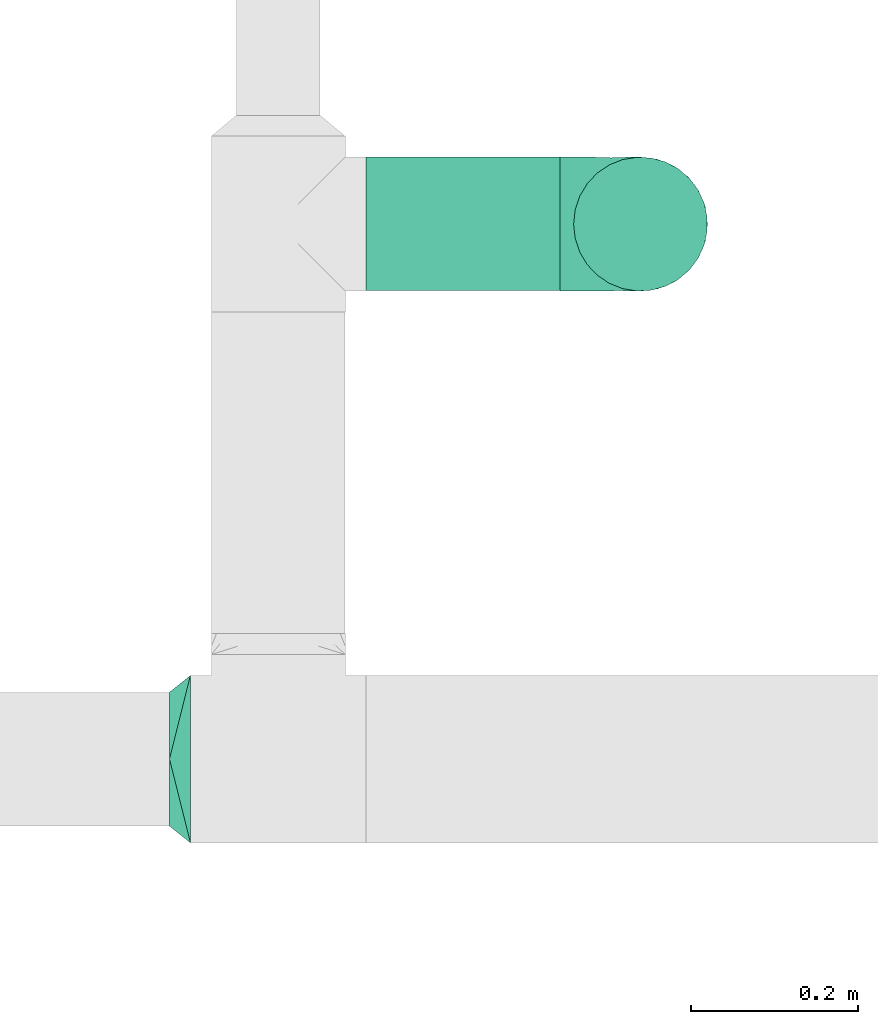
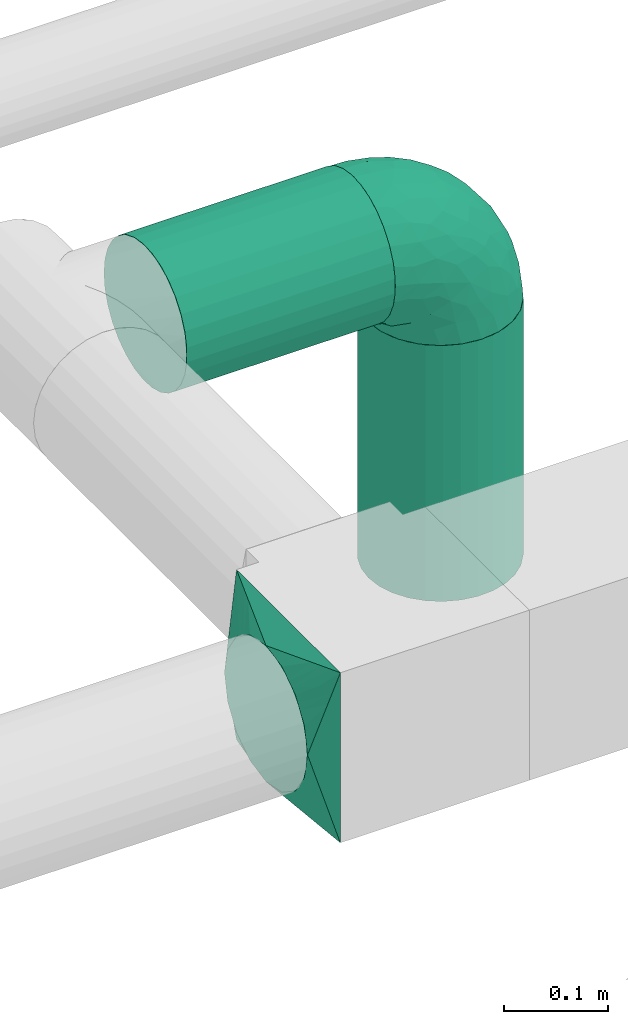
# One storey, part 8 of 12: 2 flow fittings, 2 flow segments.
"""IFC2X3 building model written with IfcOpenShell, lengths in millimetres."""

import ifcopenshell
import ifcopenshell.guid

model = None  # the IFC model being written
_history = None  # IfcOwnerHistory: only IFC2X3 demands one
_inside = {}  # id of a spatial element -> (the spatial element, [elements in it])
_under = {}  # id of a project, library or spatial element -> (it, [spatial elements below it])
_declared = {}  # id of a project -> (the project, [libraries it declares])
_typed = {}  # id of a type object -> (the type object, [elements of that type])
_made_of = {}  # id of a material, layer set ... -> (it, [elements and type objects made of it])


def new_model(schema):
    """Start an empty IFC model of exactly this schema.

    Asked for "IFC4X3", IfcOpenShell would pick the latest addendum, in which some entities
    have other attributes; the version numbers below select the first issue.
    IFC2X3 requires an IfcOwnerHistory on every rooted entity: one is made here for all.
    """
    global model, _history
    if schema == "IFC4X3":
        model = ifcopenshell.file(schema_version=(4, 3, 0, 0))
    else:
        model = ifcopenshell.file(schema=schema)
    _inside.clear()
    _under.clear()
    _declared.clear()
    _typed.clear()
    _made_of.clear()
    _history = None
    if model.schema == "IFC2X3":
        org = make("IfcOrganization", Name="unknown")
        user = make(
            "IfcPersonAndOrganization",
            ThePerson=make("IfcPerson", FamilyName="unknown"),
            TheOrganization=org,
        )
        app = make(
            "IfcApplication",
            ApplicationDeveloper=org,
            Version="unknown",
            ApplicationFullName="unknown",
            ApplicationIdentifier="unknown",
        )
        _history = make(
            "IfcOwnerHistory",
            OwningUser=user,
            OwningApplication=app,
            ChangeAction="ADDED",
            CreationDate=0,
        )
    return model


def make(cls, **values):
    """One entity of the class cls with the attributes given. An attribute that is None is left unset."""
    return model.create_entity(
        cls, **{name: value for name, value in values.items() if value is not None}
    )


def entity(cls, *values):
    """Any entity or typed value of the class cls, its attributes in the order of the schema. None: left unset."""
    e = model.create_entity(cls)
    for i, value in enumerate(values):
        if value is not None:
            e[i] = value
    return e


def rooted(cls, **values):
    """An entity with a GlobalId (a new one), such as an element, a storey or a relation."""
    return make(cls, GlobalId=ifcopenshell.guid.new(), OwnerHistory=_history, **values)


def si_unit(unit_type, name, prefix=None):
    """IfcSIUnit, for example si_unit("LENGTHUNIT", "METRE", prefix="MILLI")."""
    return make("IfcSIUnit", UnitType=unit_type, Prefix=prefix, Name=name)


def converted_unit(unit_type, name, factor, base, dimensions=None, offset=None):
    """IfcConversionBasedUnit, such as the inch: factor (a typed value) times the base unit."""
    return make(
        "IfcConversionBasedUnit"
        if offset is None
        else "IfcConversionBasedUnitWithOffset",
        ConversionOffset=offset,
        Dimensions=None
        if dimensions is None
        else entity("IfcDimensionalExponents", *dimensions),
        UnitType=unit_type,
        Name=name,
        ConversionFactor=make(
            "IfcMeasureWithUnit", ValueComponent=factor, UnitComponent=base
        ),
    )


def derived_unit(unit_type, elements):
    """IfcDerivedUnit: a product of units, each with its exponent."""
    return make(
        "IfcDerivedUnit",
        Elements=[
            make("IfcDerivedUnitElement", Unit=unit, Exponent=power)
            for unit, power in elements
        ],
        UnitType=unit_type,
    )


def assignment(units):
    """IfcUnitAssignment: the units of a project."""
    return None if units is None else make("IfcUnitAssignment", Units=units)


def point(xyz):
    """IfcCartesianPoint."""
    return None if xyz is None else make("IfcCartesianPoint", Coordinates=xyz)


def direction(xyz):
    """IfcDirection."""
    return None if xyz is None else make("IfcDirection", DirectionRatios=xyz)


def frame(location, z_axis=None, x_axis=None):
    """IfcAxis2Placement3D, a coordinate frame: its origin and axes. An axis left out is left unset."""
    return make(
        "IfcAxis2Placement3D",
        Location=point(location),
        Axis=direction(z_axis),
        RefDirection=direction(x_axis),
    )


def frame_2d(location, x_axis=None):
    """IfcAxis2Placement2D, a coordinate frame in the plane: its origin and x axis."""
    return make(
        "IfcAxis2Placement2D", Location=point(location), RefDirection=direction(x_axis)
    )


def origin():
    """The frame at (0, 0, 0) with its axes left unset."""
    return frame((0.0, 0.0, 0.0))


def origin_2d_with_axis():
    """The frame at (0, 0) in the plane with the x axis (1, 0) written out."""
    return frame_2d((0.0, 0.0), x_axis=(1.0, 0.0))


def place(relative_to, where):
    """IfcLocalPlacement: puts the frame where relative to a parent placement (None: the world)."""
    return make(
        "IfcLocalPlacement", PlacementRelTo=relative_to, RelativePlacement=where
    )


def context(
    kind, dimensions, precision=None, world=None, true_north=None, identifier=None
):
    """IfcGeometricRepresentationContext, for example the 3D "Model" context."""
    return make(
        "IfcGeometricRepresentationContext",
        ContextIdentifier=identifier,
        ContextType=kind,
        CoordinateSpaceDimension=dimensions,
        Precision=precision,
        WorldCoordinateSystem=world,
        TrueNorth=true_north,
    )


def subcontext(parent, identifier, kind, view, scale=None):
    """IfcGeometricRepresentationSubContext, for example "Body" below "Model"."""
    return make(
        "IfcGeometricRepresentationSubContext",
        ContextIdentifier=identifier,
        ContextType=kind,
        ParentContext=parent,
        TargetScale=scale,
        TargetView=view,
    )


def project(units=None, contexts=None):
    """IfcProject with its units and contexts."""
    return rooted(
        "IfcProject",
        Name="project",
        RepresentationContexts=contexts,
        UnitsInContext=assignment(units),
    )


def spatial(cls, under=None, at=None, **own):
    """A site, building, storey or space (cls), placed at a placement, below another one or the project."""
    s = rooted(cls, ObjectPlacement=at, **own)
    if under is not None:
        _under.setdefault(under.id(), (under, []))[1].append(s)
    return s


def profile(cls, at=None, kind="AREA", **sizes):
    """A parametric profile (cls). Its sizes go by their IFC names, for example OverallWidth=200.0."""
    return make(cls, ProfileType=kind, Position=at, **sizes)


def circle(**sizes):
    """IfcCircleProfileDef."""
    return profile("IfcCircleProfileDef", **sizes)


def extrude(swept, where, along, depth):
    """IfcExtrudedAreaSolid: the profile swept, set in the frame where, extruded along a direction by depth."""
    return make(
        "IfcExtrudedAreaSolid",
        SweptArea=swept,
        Position=where,
        ExtrudedDirection=direction(along),
        Depth=depth,
    )


def faces_of(points, faces, orient=None, outer=None):
    """IfcFace entities. A face is a list of loops; a loop is a list of indices into points, from 0.

    orient and outer hold one flag for each loop. By default every Orientation is true, the
    first loop of a face is its IfcFaceOuterBound and the others are IfcFaceBound.
    """
    made = []
    for i, loops in enumerate(faces):
        bounds = []
        for j, loop in enumerate(loops):
            is_outer = j == 0 if outer is None else outer[i][j]
            bounds.append(
                make(
                    "IfcFaceOuterBound" if is_outer else "IfcFaceBound",
                    Bound=make("IfcPolyLoop", Polygon=[points[k] for k in loop]),
                    Orientation=True if orient is None else orient[i][j],
                )
            )
        made.append(make("IfcFace", Bounds=bounds))
    return made


def faceted_brep(points, faces, orient=None, outer=None, voids=None):
    """IfcFacetedBrep: a solid bounded by flat faces; with voids (closed shells), ...WithVoids."""
    shared = [point(p) for p in points]
    hull = make("IfcClosedShell", CfsFaces=faces_of(shared, faces, orient, outer))
    if voids is None:
        return make("IfcFacetedBrep", Outer=hull)
    return make(
        "IfcFacetedBrepWithVoids",
        Outer=hull,
        Voids=[
            make(cls, CfsFaces=faces_of(shared, fs, o, b)) for cls, fs, o, b in voids
        ],
    )


def shape(context_of_items, identifier, shape_type, items):
    """IfcShapeRepresentation: the items that make up one representation, for example the "Body"."""
    return make(
        "IfcShapeRepresentation",
        ContextOfItems=context_of_items,
        RepresentationIdentifier=identifier,
        RepresentationType=shape_type,
        Items=items,
    )


def source(mapping_origin, context_of_items, identifier, shape_type, items):
    """IfcRepresentationMap: a shape defined once, which mapped items show again and again."""
    return make(
        "IfcRepresentationMap",
        MappingOrigin=mapping_origin,
        MappedRepresentation=shape(context_of_items, identifier, shape_type, items),
    )


def transform(
    local_origin,
    x_axis=None,
    y_axis=None,
    z_axis=None,
    scale=None,
    scale2=None,
    scale3=None,
    uniform=True,
):
    """IfcCartesianTransformationOperator3D, or its non-uniform kind. x_axis, y_axis, z_axis: its Axis1, 2, 3."""
    if uniform:
        return make(
            "IfcCartesianTransformationOperator3D",
            Axis1=direction(x_axis),
            Axis2=direction(y_axis),
            LocalOrigin=point(local_origin),
            Scale=scale,
            Axis3=direction(z_axis),
        )
    return make(
        "IfcCartesianTransformationOperator3DnonUniform",
        Axis1=direction(x_axis),
        Axis2=direction(y_axis),
        LocalOrigin=point(local_origin),
        Scale=scale,
        Axis3=direction(z_axis),
        Scale2=scale2,
        Scale3=scale3,
    )


def mapped(mapping_source, mapping_target):
    """IfcMappedItem: shows the shape of a source again, moved by a transform."""
    return make(
        "IfcMappedItem", MappingSource=mapping_source, MappingTarget=mapping_target
    )


def material(Name=None, Category=None):
    """IfcMaterial."""
    return make("IfcMaterial", Name=Name, Category=Category)


def made_of(thing, what):
    """Note that an element or type object is made of a material, layer set ...; save() writes the relation."""
    if what is not None:
        _made_of.setdefault(what.id(), (what, []))[1].append(thing)
    return thing


def type_object(cls, material=None, **own):
    """A type object (cls), such as IfcWallType, which elements share."""
    return made_of(rooted(cls, **own), material)


def type_shapes(of_type, sources):
    """Give a type object the sources (RepresentationMaps) that its elements show as mapped items."""
    of_type.RepresentationMaps = sources


def element(
    cls,
    number,
    at=None,
    inside=None,
    cuts=None,
    type_object=None,
    material=None,
    context=None,
    identifier="Body",
    shape_type=None,
    held_by="IfcProductDefinitionShape",
    body=None,
    shapes=None,
    **own,
):
    """One element of the class cls, such as IfcWall. Its Tag is "e" and its number.

    at: its placement. inside: the storey or other place that contains it. cuts: it is an
    opening in that element (IfcRelVoidsElement). A single representation is given by context,
    identifier, shape_type and body (its items); several are given by shapes. held_by: the class
    of the entity that holds the representations. save() writes the other relations.
    """
    e = rooted(cls, Tag="e%d" % number, ObjectPlacement=at, **own)
    if body is not None:
        shapes = [shape(context, identifier, shape_type, body)]
    if shapes is not None:
        e.Representation = make(held_by, Representations=shapes)
    if inside is not None:
        _inside.setdefault(inside.id(), (inside, []))[1].append(e)
    if cuts is not None:
        rooted(
            "IfcRelVoidsElement", RelatingBuildingElement=cuts, RelatedOpeningElement=e
        )
    if type_object is not None:
        _typed.setdefault(type_object.id(), (type_object, []))[1].append(e)
    return made_of(e, material)


def aggregate(whole, parts):
    """IfcRelAggregates: a whole, such as a stair, and the parts it consists of."""
    return rooted("IfcRelAggregates", RelatingObject=whole, RelatedObjects=parts)


def save(model, path):
    """Write the relations noted so far, then the file.

    IfcRelAggregates (storeys below a building ...), IfcRelContainedInSpatialStructure (elements
    in a storey), IfcRelDefinesByType, IfcRelAssociatesMaterial and IfcRelDeclares: one each for
    every whole, place, type object, material and project.
    """
    for whole, parts in _under.values():
        aggregate(whole, parts)
    for where, things in _inside.values():
        rooted(
            "IfcRelContainedInSpatialStructure",
            RelatedElements=things,
            RelatingStructure=where,
        )
    for kind, things in _typed.values():
        rooted("IfcRelDefinesByType", RelatedObjects=things, RelatingType=kind)
    for what, things in _made_of.values():
        rooted("IfcRelAssociatesMaterial", RelatedObjects=things, RelatingMaterial=what)
    for by, libraries in _declared.values():
        rooted("IfcRelDeclares", RelatingContext=by, RelatedDefinitions=libraries)
    model.write(path)


model = new_model("IFC2X3")

# Units and contexts
model_context = context("Model", 3, precision=0.01, world=origin(), true_north=direction((6.12303176911189e-17, 1.0)))
body_context = subcontext(model_context, "Body", "Model", "MODEL_VIEW")
ifc_project = project(units=[si_unit("LENGTHUNIT", "METRE", prefix="MILLI"), si_unit("AREAUNIT", "SQUARE_METRE"), si_unit("VOLUMEUNIT", "CUBIC_METRE"), converted_unit("PLANEANGLEUNIT", "DEGREE", entity("IfcRatioMeasure", 0.0174532925199433), si_unit("PLANEANGLEUNIT", "RADIAN"), dimensions=[0, 0, 0, 0, 0, 0, 0]), si_unit("MASSUNIT", "GRAM", prefix="KILO"), derived_unit("MASSDENSITYUNIT", [(si_unit("MASSUNIT", "GRAM", prefix="KILO"), 1), (si_unit("LENGTHUNIT", "METRE"), -3)]), si_unit("TIMEUNIT", "SECOND"), si_unit("FREQUENCYUNIT", "HERTZ"), si_unit("THERMODYNAMICTEMPERATUREUNIT", "DEGREE_CELSIUS"), derived_unit("THERMALTRANSMITTANCEUNIT", [(si_unit("MASSUNIT", "GRAM", prefix="KILO"), 1), (si_unit("THERMODYNAMICTEMPERATUREUNIT", "KELVIN"), -1), (si_unit("TIMEUNIT", "SECOND"), -3)]), derived_unit("VOLUMETRICFLOWRATEUNIT", [(si_unit("LENGTHUNIT", "METRE"), 3), (si_unit("TIMEUNIT", "SECOND"), -1)]), si_unit("ELECTRICCURRENTUNIT", "AMPERE"), si_unit("ELECTRICVOLTAGEUNIT", "VOLT"), si_unit("POWERUNIT", "WATT"), si_unit("FORCEUNIT", "NEWTON", prefix="KILO"), si_unit("ILLUMINANCEUNIT", "LUX"), si_unit("LUMINOUSFLUXUNIT", "LUMEN"), si_unit("LUMINOUSINTENSITYUNIT", "CANDELA"), derived_unit("USERDEFINED", [(si_unit("MASSUNIT", "GRAM", prefix="KILO"), -1), (si_unit("LENGTHUNIT", "METRE"), -2), (si_unit("TIMEUNIT", "SECOND"), 3), (si_unit("LUMINOUSFLUXUNIT", "LUMEN"), 1)]), derived_unit("LINEARVELOCITYUNIT", [(si_unit("LENGTHUNIT", "METRE"), 1), (si_unit("TIMEUNIT", "SECOND"), -1)]), si_unit("PRESSUREUNIT", "PASCAL"), derived_unit("USERDEFINED", [(si_unit("LENGTHUNIT", "METRE"), -2), (si_unit("MASSUNIT", "GRAM", prefix="KILO"), 1), (si_unit("TIMEUNIT", "SECOND"), -2)])], contexts=[model_context])

# Site, building, storey
site_placement = place(None, origin())
site = spatial("IfcSite", under=ifc_project, at=site_placement, CompositionType="ELEMENT")
building_placement = place(site_placement, origin())
building = spatial("IfcBuilding", under=site, at=building_placement, CompositionType="ELEMENT")
storey_placement = place(building_placement, frame((0.0, 0.0, 4000.0)))
storey = spatial("IfcBuildingStorey", under=building, at=storey_placement, Name="01 Level", CompositionType="ELEMENT", Elevation=4000.0)

# Flow segments
duct_segment_type = type_object("IfcDuctSegmentType", Name="Round Duct:Air", PredefinedType="NOTDEFINED")
flow_segment_1_placement = place(storey_placement, frame((23290.9900708518, -67948.8402110238, 2918.40472776409)))
element("IfcFlowSegment", 1, at=flow_segment_1_placement, inside=storey, type_object=duct_segment_type, Name="Round Duct:Air", ObjectType="Round Duct:Air", context=body_context, shape_type="SweptSolid", body=[
    extrude(circle(Radius=80.0, at=frame_2d((0.0, 1.08286712929839e-12), x_axis=(1.0, 0.0))), frame((0.0, 81.595272235915, 81.595272235915), z_axis=(1.0, 0.0, 0.0), x_axis=(0.0, 1.0, 0.0)), (0.0, 0.0, 1.0), 231.770344008329),
])
flow_segment_2_placement = place(storey_placement, frame((23537.1651426242, -67948.8402110238, 2603.07847999999)))
element("IfcFlowSegment", 2, at=flow_segment_2_placement, inside=storey, type_object=duct_segment_type, Name="Round Duct:Air", ObjectType="Round Duct:Air", context=body_context, shape_type="SweptSolid", body=[
    extrude(circle(Radius=79.9999999999999, at=origin_2d_with_axis()), frame((81.595272235915, 81.595272235915, 0.0), z_axis=(0.0, 0.0, 1.0), x_axis=(-1.0, 0.0, 0.0)), (0.0, 0.0, 1.0), 300.921520000008),
])

# Flow fittings
duct_fitting_type_1 = type_object("IfcDuctFittingType", Name="Air_Elbow short_Circ", PredefinedType="NOTDEFINED")
shared_shape_1 = source(origin(), body_context, "Body", "Brep", [
    faceted_brep([(-96.0, 0.0, -80.0), (-96.0, -20.7055236082018, -77.2740661031254), (-96.0, -40.0, -69.2820323027551), (-96.0, -56.5685424949239, -56.5685424949238), (-96.0, -69.2820323027551, -40.0), (-96.0, -77.2740661031255, -20.7055236082016), (-96.0, -80.0, 0.0), (-96.0, -77.2740661031253, 20.7055236082021), (-96.0, -69.2820323027549, 40.0), (-96.0, -56.5685424949235, 56.5685424949241), (-96.0, -40.0, 69.2820323027553), (-96.0, -30.3527618041005, 73.2780492029404), (-96.0, -20.7055236082013, 77.2740661031256), (-96.0, 0.0, 80.0), (-96.0, 20.705523608202, 77.2740661031254), (-96.0, 40.0, 69.2820323027549), (-96.0, 56.568542494924, 56.5685424949236), (-96.0, 69.2820323027553, 40.0), (-96.0, 77.2740661031256, 20.7055236082014), (-96.0, 80.0, 0.0), (-96.0, 77.2740661031254, -20.7055236082019), (-96.0, 69.282032302755, -40.0), (-96.0, 56.5685424949237, -56.5685424949239), (-96.0, 40.0, -69.2820323027552), (-96.0, 20.7055236082015, -77.2740661031255), (0.0, -96.0, -80.0), (20.7055236082025, -96.0, -77.2740661031255), (40.0, -96.0, -69.2820323027552), (56.5685424949246, -96.0, -56.5685424949239), (69.2820323027559, -96.0, -40.0), (77.2740661031264, -96.0, -20.7055236082019), (80.0, -96.0, 0.0), (77.2740661031265, -96.0, 20.7055236082014), (69.2820323027562, -96.0, 40.0), (56.5685424949249, -96.0, 56.5685424949236), (40.0, -96.0, 69.2820323027549), (20.7055236082029, -96.0, 77.2740661031254), (0.0, -96.0, 80.0), (-20.7055236082004, -96.0, 77.2740661031256), (-40.0, -96.0, 69.2820323027553), (-56.5685424949226, -96.0, 56.5685424949241), (-69.2820323027539, -96.0, 40.0), (-77.2740661031244, -96.0, 20.7055236082021), (-80.0, -96.0, 0.0), (-77.2740661031245, -96.0, -20.7055236082016), (-69.2820323027542, -96.0, -40.0), (-56.5685424949229, -96.0, -56.5685424949238), (-40.0, -96.0, -69.2820323027551), (-30.3527618041, -96.0, -73.2780492029402), (-20.7055236082008, -96.0, -77.2740661031254), (-69.6571465232348, -6.28172173912476, 79.9611058756859), (-66.7862289407348, 74.1387210661139, 22.9795507758541), (-78.4902527850466, 65.2482264041437, 44.9229732355936), (-55.1380888291464, 64.4450584799279, 39.5029426177976), (-75.1250134759213, -46.3506195730757, 68.0011973810265), (-79.9123689128389, -22.4151301859584, 77.2816866630488), (-67.1316735243184, 51.7530432423058, 58.5204707533666), (-62.9760666105318, 34.5362195419601, 70.0448030595901), (-46.2820694578435, 43.7397705581167, 60.5188244193914), (-76.2276812833835, 77.3969248578635, 0.0), (-50.4478480619551, 74.0029454268759, 0.0), (-6.30632028234235, -70.6421404093778, 79.9513108199466), (-27.189372084162, -68.980536479128, 76.8941402015288), (-29.8609237116382, 28.9682345099716, 65.8760199345924), (-47.7584488981354, 13.6212410427434, 76.3881123659885), (43.7397637815864, -46.2820598522933, 60.518827155348), (51.7530435574228, -67.1316742002235, 58.5204705859065), (57.6005967886466, -33.4719572927763, 39.0176496769077), (-74.2591571701267, 14.3645886695287, 78.2829835259588), (7.8513563843086, 42.4938374080907, 21.3232874317503), (23.3846344985257, 27.9066135199674, 24.7887114209846), (28.4507934888335, 28.4507934888321, 0.0), (-84.190871651952, -70.905997349447, 41.7100461919055), (10.21505333872, 32.0754161621096, 38.020212353501), (-0.0180155578363953, 25.9284255475521, 53.836744023285), (24.7272484782103, 2.06889411058577, 53.4325037134459), (-41.7574890626937, -15.123136403511, 79.988056483004), (-64.5619855594544, -27.52018553659, 77.2892967298799), (-8.0, 56.420471066061, 0.0), (-29.2239240309769, 65.2117082464685, 0.0), (-24.5336756868846, 60.9669573051438, 23.5003835585885), (-16.4008295437786, -51.3122057461681, 79.8609584412684), (-84.6862915010143, -84.6862915010152, 0.0), (-83.0529092063249, -83.0529092103045, 19.0855009657076), (-82.4185651555764, -62.2587017800419, 53.3339952483838), (-46.3022193149449, -75.902750025661, 67.8445262622594), (-9.5260688639158, 47.7232209131232, 35.4187162694583), (74.1387213421635, -66.7862279048973, 22.9795492840646), (34.536215572589, -62.976064096567, 70.0448048426748), (14.3645870599314, -74.259154996167, 78.2829837700474), (65.2482273833467, -78.4902510979302, 44.9229715327465), (-25.6317751341749, -1.2640655514879, 76.9124052095498), (-12.3935655196116, -25.4017250572252, 78.8652642576962), (60.9669574479924, -24.5336725945725, 23.5003789659965), (64.4450597015273, -55.1380839274934, 39.5029384026545), (69.8186739706361, -42.5625104806759, 16.7980672722629), (77.3969247188647, -76.2276802275763, 0.0), (74.002945426877, -50.4478480619565, 0.0), (-52.4774893100348, -53.0631556360015, 72.0041598972686), (-66.5995156060253, -66.5995146556305, 58.6370817132137), (-76.4857465466113, -78.9385356944492, 38.5867538667356), (-62.2587016209511, -82.4185645906685, 53.3339956492136), (13.6212369177471, -47.7584433090926, 76.3881128402526), (28.9682276847195, -29.8609133580269, 65.8760207540895), (-6.49930484510329, 53.7890406240985, 15.4645725223014), (-33.731289034344, -40.0214486160993, 79.0537019298314), (46.1336936566893, -26.2441492635858, 50.151541479116), (50.0005984633279, -1.26038287501495, 17.5763945268078), (56.4204710660622, -8.0, 0.0), (42.4356322774479, 10.225396744416, 0.0), (-45.4536887619888, 68.8356359385787, 23.6914879663761), (-33.3493864711472, 57.4572215948989, 39.1720709545353), (35.9683398342664, 11.0724559744972, 30.5391080332169), (-26.2441652621668, 46.1336984778153, 50.1515448602929), (36.6749123583047, 17.5982116941791, 14.5644188861001), (65.2117082464696, -29.2239240309784, 0.0), (49.5968730216335, -12.1440064858134, 34.8325942562253), (-47.1533280807863, -29.0746114834461, 78.9127210009486), (-0.981722938535007, -51.3162880079176, 79.4920802366619), (-1.95170750213435, -1.95169859379814, 70.9272590604952), (12.4951682569875, -20.0804783439543, 71.2292489374933), (13.0725391330592, -1.13338064801589, 63.5790506070627), (-1.93327092594732, 13.4823821925323, 63.7412032706882), (-18.9298205951927, 13.0048872663631, 70.6672094580024), (10.2253967444173, 42.4356322774466, 0.0), (-68.9805369123341, -27.1893702897943, -76.8941406355589), (-46.3506180288022, -75.1250185023919, -68.0011970559212), (-27.5201921618733, -64.5619784506715, -77.2892959136582), (-22.4151342180024, -79.9123577737124, -77.2816862456941), (-74.2591561090454, 14.364589592643, -78.2829832920378), (-66.78622820047, 74.1387209331735, -22.9795507950237), (-42.5625109127564, 69.8186736490614, -16.7980693145318), (-70.6421421271429, -6.30631801763141, -79.9513108797024), (-1.2640784754681, -25.6317655571971, -76.9124065444174), (-15.1231475192353, -41.7574898106582, -79.9880566497423), (-25.401718902627, -12.3935649209934, -78.8652635038296), (-82.4185656924104, -62.258701559575, -53.3339952529289), (-66.5995166501766, -66.5995137008527, -58.6370816545605), (-78.9385361639639, -76.4857467527193, -38.5867530236755), (53.7890400497189, -6.49930371043273, -15.4645720709197), (60.9669567069012, -24.5336743104721, -23.5003834743896), (-24.5336751436549, 60.9669572920351, -23.5003828649414), (-55.1380878256228, 64.4450583029017, -39.5029424837467), (-46.2820677406335, 43.7397707662098, -60.5188237522514), (-26.2441631797834, 46.1336980827234, -50.1515441608816), (-29.8609212227281, 28.9682353164184, -65.8760186412515), (74.1387206827049, -66.7862275406284, -22.9795512458422), (-40.0214489824224, -33.7312845774564, -79.0537024061946), (-78.4902524468744, 65.2482264004152, -44.9229731872606), (-75.902751427461, -46.3022186029078, -67.8445263463497), (-70.9059970555813, -84.1908706304995, -41.7100473389448), (-62.9760652707231, 34.536220162299, -70.044802546446), (-67.1316724627346, 51.7530434014037, -58.5204704180807), (-33.4719630839568, 57.6005950429912, -39.0176564793206), (-51.3122062597491, -16.4008248291117, -79.8609586691244), (-6.28171714934502, -69.65712797409, -79.9611061760713), (51.7530427306645, -67.1316703492073, -58.5204706539109), (-83.0529092397056, -83.0529091932979, -19.0855009185769), (68.8356349913375, -45.45368838847, -23.6914905340598), (-62.258701383479, -82.4185638376438, -53.3339962098694), (34.53621889603, -62.9760621802168, -70.0448028055675), (-1.26038544288408, 50.0005998980998, -17.5763953891677), (14.3645887716112, -74.2591526334116, -78.2829833202131), (13.6212385978137, -47.75844096294, -76.3881120677864), (65.2482261461557, -78.4902526871683, -44.9229735979605), (32.0754071702863, 10.2150656939878, -38.0202105656364), (25.9284207554091, -0.0180077987247146, -53.8367428868672), (2.068884460932, 24.7272580800759, -53.4325021883878), (47.723215348146, -9.52606271707191, -35.4187195087105), (42.4938359077841, 7.8513587520169, -21.3232866357369), (27.9066094773716, 23.3846413342612, -24.7887058003424), (28.9682309044935, -29.8609168472814, -65.8760199178674), (64.4450577206072, -55.1380878066959, -39.5029434692504), (-53.063150048133, -52.4774843719861, -72.0041634993662), (43.7397687897612, -46.2820667462245, -60.5188250739327), (-47.7584463040963, 13.6212426330217, -76.3881115880261), (57.4572201066452, -33.3493827160302, -39.1720708806551), (11.0724494499294, 35.9683446288498, -30.5391089716619), (46.1336964749623, -26.2441642243134, -50.1515465265606), (17.5982028158329, 36.6749194460897, -14.5644209948051), (-12.1440097531109, 49.5968729214507, -34.8325978072281), (-29.0746218055845, -47.1533256390974, -78.912719851915), (-51.3162911259858, -0.981717610547608, -79.4920798409907), (-1.95170139871169, -1.95169735730944, -70.9272563527003), (-20.0804667507281, 12.4951842966219, -71.2292388196267), (-1.13337124471279, 13.072540998247, -63.5790448193562), (13.4823844636247, -1.93327501577089, -63.7412039856557), (13.0048800657406, -18.9298191902065, -70.6672121474654)], [[[0, 1, 2, 3, 4, 5, 6, 7, 8, 9, 10, 11, 12, 13, 14, 15, 16, 17, 18, 19, 20, 21, 22, 23, 24]], [[25, 26, 27, 28, 29, 30, 31, 32, 33, 34, 35, 36, 37, 38, 39, 40, 41, 42, 43, 44, 45, 46, 47, 48, 49]], [[50, 13, 12]], [[51, 52, 53]], [[10, 54, 55]], [[56, 57, 58]], [[59, 51, 60]], [[61, 62, 38]], [[63, 57, 64]], [[65, 66, 67]], [[17, 16, 52]], [[15, 57, 56]], [[14, 13, 68]], [[69, 70, 71]], [[8, 7, 72]], [[68, 64, 57]], [[73, 74, 75]], [[76, 50, 77]], [[57, 15, 14]], [[9, 54, 10]], [[55, 12, 11, 10]], [[78, 79, 80]], [[62, 61, 81]], [[82, 83, 6]], [[63, 58, 57]], [[83, 7, 6]], [[8, 72, 84]], [[56, 16, 15]], [[84, 9, 8]], [[62, 85, 39]], [[86, 74, 73]], [[59, 18, 51]], [[18, 17, 51]], [[32, 87, 33]], [[35, 34, 66]], [[36, 88, 89]], [[90, 34, 33]], [[88, 36, 35]], [[91, 76, 92]], [[90, 33, 87]], [[93, 94, 95]], [[35, 66, 88]], [[32, 96, 87]], [[85, 40, 39]], [[87, 97, 95]], [[98, 99, 85]], [[41, 100, 42]], [[42, 100, 83]], [[101, 99, 100]], [[102, 88, 103]], [[43, 83, 82]], [[104, 78, 80]], [[38, 62, 39]], [[98, 85, 62]], [[92, 76, 105]], [[65, 106, 103]], [[101, 41, 40]], [[37, 61, 38]], [[107, 108, 109]], [[51, 53, 110]], [[37, 36, 89]], [[79, 110, 80]], [[110, 79, 60]], [[111, 110, 53]], [[112, 70, 73]], [[113, 86, 111]], [[71, 114, 109]], [[75, 103, 106]], [[93, 95, 115]], [[37, 89, 61]], [[108, 93, 115]], [[67, 93, 116]], [[107, 116, 93]], [[13, 50, 68]], [[117, 76, 77]], [[98, 117, 77]], [[99, 54, 84]], [[40, 85, 101]], [[98, 54, 99]], [[105, 62, 81]], [[89, 118, 61]], [[88, 66, 65]], [[94, 66, 90]], [[16, 56, 52]], [[111, 53, 56]], [[76, 64, 50]], [[64, 76, 91]], [[119, 92, 120]], [[61, 118, 81]], [[120, 121, 119]], [[116, 112, 75]], [[121, 122, 119]], [[119, 122, 123]], [[113, 63, 74]], [[119, 123, 91]], [[86, 113, 74]], [[122, 121, 75]], [[54, 98, 77]], [[105, 98, 62]], [[59, 19, 18]], [[97, 87, 96]], [[32, 31, 96]], [[102, 89, 88]], [[14, 68, 57]], [[64, 68, 50]], [[41, 101, 100]], [[99, 101, 85]], [[9, 84, 54]], [[100, 99, 72]], [[81, 92, 105]], [[102, 92, 118]], [[81, 118, 92]], [[102, 118, 89]], [[84, 72, 99]], [[83, 100, 72]], [[72, 7, 83]], [[42, 83, 43]], [[17, 52, 51]], [[53, 52, 56]], [[34, 90, 66]], [[94, 90, 87]], [[55, 54, 77]], [[55, 50, 12]], [[55, 77, 50]], [[60, 51, 110]], [[80, 110, 111]], [[86, 104, 80]], [[58, 113, 111]], [[111, 86, 80]], [[73, 69, 86]], [[69, 73, 70]], [[112, 73, 75]], [[69, 124, 104]], [[108, 107, 93]], [[112, 114, 70]], [[93, 67, 94]], [[112, 107, 114]], [[70, 114, 71]], [[109, 114, 107]], [[106, 116, 75]], [[116, 107, 112]], [[94, 67, 66]], [[67, 116, 106]], [[115, 95, 97]], [[69, 104, 86]], [[78, 104, 124]], [[69, 71, 124]], [[87, 95, 94]], [[88, 65, 103]], [[106, 65, 67]], [[56, 58, 111]], [[113, 58, 63]], [[117, 105, 76]], [[105, 117, 98]], [[63, 64, 123]], [[119, 91, 92]], [[91, 123, 64]], [[74, 63, 122]], [[123, 122, 63]], [[74, 122, 75]], [[121, 103, 75]], [[103, 121, 120]], [[120, 102, 103]], [[102, 120, 92]], [[1, 125, 2]], [[126, 127, 128]], [[129, 0, 24]], [[130, 60, 131]], [[0, 132, 1]], [[133, 134, 135]], [[136, 137, 138]], [[139, 108, 140]], [[3, 136, 4]], [[141, 142, 131]], [[138, 5, 4]], [[143, 144, 145]], [[30, 29, 146]], [[135, 134, 147]], [[148, 21, 130]], [[149, 3, 2]], [[20, 59, 130]], [[45, 44, 150]], [[151, 23, 152]], [[143, 152, 153]], [[152, 23, 22]], [[151, 24, 23]], [[125, 132, 154]], [[21, 148, 22]], [[155, 25, 49]], [[151, 129, 24]], [[20, 130, 21]], [[156, 28, 27]], [[157, 82, 6]], [[115, 158, 140]], [[157, 44, 43]], [[5, 138, 157]], [[150, 159, 45]], [[160, 27, 26]], [[161, 78, 124]], [[45, 159, 46]], [[128, 49, 48, 47]], [[2, 125, 149]], [[134, 155, 127]], [[162, 163, 160]], [[29, 28, 164]], [[126, 47, 46]], [[165, 166, 167]], [[25, 162, 26]], [[166, 165, 168]], [[132, 125, 1]], [[108, 115, 140]], [[169, 170, 71]], [[171, 160, 163]], [[27, 160, 156]], [[146, 164, 172]], [[173, 137, 149]], [[97, 96, 146]], [[171, 174, 160]], [[175, 151, 145]], [[160, 174, 156]], [[173, 149, 125]], [[47, 126, 128]], [[158, 115, 97]], [[6, 5, 157]], [[146, 172, 158]], [[96, 30, 146]], [[176, 158, 172]], [[177, 170, 165]], [[178, 168, 176]], [[71, 179, 124]], [[167, 145, 144]], [[141, 131, 79]], [[96, 31, 30]], [[78, 141, 79]], [[153, 141, 180]], [[161, 180, 141]], [[25, 155, 162]], [[147, 134, 181]], [[173, 181, 127]], [[137, 126, 159]], [[3, 149, 136]], [[173, 126, 137]], [[147, 125, 154]], [[129, 182, 132]], [[151, 152, 143]], [[142, 152, 148]], [[28, 156, 164]], [[176, 172, 156]], [[134, 163, 155]], [[163, 134, 133]], [[183, 135, 184]], [[132, 182, 154]], [[184, 185, 183]], [[180, 177, 167]], [[185, 186, 183]], [[183, 186, 187]], [[178, 171, 166]], [[183, 187, 133]], [[168, 178, 166]], [[186, 185, 167]], [[126, 173, 127]], [[147, 173, 125]], [[60, 130, 59]], [[20, 19, 59]], [[0, 129, 132]], [[175, 129, 151]], [[26, 162, 160]], [[163, 162, 155]], [[4, 136, 138]], [[137, 136, 149]], [[46, 159, 126]], [[138, 137, 150]], [[154, 135, 147]], [[175, 135, 182]], [[154, 182, 135]], [[175, 182, 129]], [[159, 150, 137]], [[157, 138, 150]], [[82, 157, 43]], [[150, 44, 157]], [[29, 164, 146]], [[172, 164, 156]], [[22, 148, 152]], [[142, 148, 130]], [[155, 128, 127]], [[128, 155, 49]], [[97, 146, 158]], [[140, 158, 176]], [[168, 139, 140]], [[174, 178, 176]], [[176, 168, 140]], [[165, 169, 168]], [[169, 165, 170]], [[177, 165, 167]], [[169, 109, 139]], [[78, 161, 141]], [[177, 179, 170]], [[141, 153, 142]], [[177, 161, 179]], [[170, 179, 71]], [[124, 179, 161]], [[144, 180, 167]], [[180, 161, 177]], [[142, 153, 152]], [[153, 180, 144]], [[79, 131, 60]], [[169, 139, 168]], [[108, 139, 109]], [[169, 71, 109]], [[130, 131, 142]], [[151, 143, 145]], [[144, 143, 153]], [[156, 174, 176]], [[178, 174, 171]], [[147, 181, 173]], [[181, 134, 127]], [[171, 163, 187]], [[183, 133, 135]], [[133, 187, 163]], [[166, 171, 186]], [[187, 186, 171]], [[166, 186, 167]], [[185, 145, 167]], [[145, 185, 184]], [[184, 175, 145]], [[175, 184, 135]]]),
])
type_shapes(duct_fitting_type_1, [shared_shape_1])
flow_fitting_1_placement = place(storey_placement, frame((23618.7604148601, -67867.2449387878, 3000.0), z_axis=(0.0, 1.0, 0.0), x_axis=(0.0, 0.0, 1.0)))
element("IfcFlowFitting", 3, at=flow_fitting_1_placement, inside=storey, type_object=duct_fitting_type_1, Name="elbow_short_001:Air_Elbow short_Circ", ObjectType="elbow_short_001:Air_Elbow short_Circ", context=body_context, shape_type="MappedRepresentation", body=[
    mapped(shared_shape_1, transform((0.0, 0.0, 0.0), scale=1.0)),
])
ifc_material = material(Name="Material_Duct")
duct_fitting_type_2 = type_object("IfcDuctFittingType", Name="Air_Multi shape transition_Circ", PredefinedType="NOTDEFINED", material=ifc_material)
shared_shape_2 = source(origin(), body_context, "Body", "Brep", [
    faceted_brep([(25.0, 0.0, -80.0), (25.0, 7.55917892584856, -78.4963858244121), (25.0, 15.1183578516973, -76.9927716488251), (25.0, 22.8665162204521, -75.4515671248636), (25.0, 26.7405954048296, -74.6809648628828), (25.0, 30.614674589207, -73.9103626009021), (25.0, 37.1031415656362, -69.5749075744073), (25.0, 43.5916085420653, -65.2394525479126), (25.0, 50.0800755184945, -60.9039975214178), (25.0, 56.5685424949236, -56.5685424949231), (25.0, 60.9039975214184, -50.0800755184939), (25.0, 65.2394525479132, -43.5916085420648), (25.0, 69.574907574408, -37.1031415656356), (25.0, 73.9103626009028, -30.6146745892065), (25.0, 75.4515671268645, -22.8665162103963), (25.0, 76.9927716528262, -15.1183578315862), (25.0, 77.7445787396197, -11.3387683736895), (25.0, 78.4963858264131, -7.55917891579276), (25.0, 80.0, 0.0), (25.0, 78.496385824413, 7.55917892584876), (25.0, 76.992771648826, 15.1183578516975), (25.0, 75.4515671248645, 22.8665162204524), (25.0, 74.6809648628837, 26.7405954048298), (25.0, 73.9103626009029, 30.6146745892072), (25.0, 69.5749075744081, 37.1031415656364), (25.0, 65.2394525479133, 43.5916085420656), (25.0, 60.9039975214185, 50.0800755184947), (25.0, 56.5685424949237, 56.5685424949239), (25.0, 50.0800755184946, 60.9039975214187), (25.0, 43.5916085420654, 65.2394525479134), (25.0, 37.1031415656362, 69.5749075744082), (25.0, 30.6146745892071, 73.910362600903), (25.0, 22.8665162103969, 75.4515671268647), (25.0, 15.1183578315867, 76.9927716528263), (25.0, 11.33876837369, 77.7445787396197), (25.0, 7.55917891579326, 78.4963858264132), (25.0, 0.0, 80.0), (25.0, -7.55917892584888, 78.496385824413), (25.0, -15.1183578516976, 76.992771648826), (25.0, -22.8665162204525, 75.4515671248644), (25.0, -26.7405954048299, 74.6809648628836), (25.0, -30.6146745892073, 73.9103626009029), (25.0, -37.1031415656365, 69.5749075744081), (25.0, -43.5916085420656, 65.2394525479133), (25.0, -50.0800755184948, 60.9039975214185), (25.0, -56.5685424949239, 56.5685424949237), (25.0, -60.9039975214187, 50.0800755184945), (25.0, -65.2394525479135, 43.5916085420653), (25.0, -69.5749075744082, 37.1031415656362), (25.0, -73.910362600903, 30.614674589207), (25.0, -75.4515671268647, 22.8665162103968), (25.0, -76.9927716528263, 15.1183578315866), (25.0, -77.7445787396197, 11.3387683736899), (25.0, -78.4963858264131, 7.55917891579322), (25.0, -80.0, 0.0), (25.0, -78.496385824413, -7.55917892584782), (25.0, -76.992771648826, -15.1183578516966), (25.0, -75.4515671248645, -22.8665162204514), (25.0, -74.6809648628837, -26.7405954048289), (25.0, -73.910362600903, -30.6146745892063), (25.0, -69.5749075744082, -37.1031415656355), (25.0, -65.2394525479134, -43.5916085420646), (25.0, -60.9039975214186, -50.0800755184938), (25.0, -56.5685424949238, -56.5685424949229), (25.0, -50.0800755184946, -60.9039975214177), (25.0, -43.5916085420654, -65.2394525479125), (25.0, -37.1031415656363, -69.5749075744073), (25.0, -30.6146745892071, -73.9103626009021), (25.0, -22.8665162103969, -75.4515671268637), (25.0, -15.1183578315867, -76.9927716528254), (25.0, -11.33876837369, -77.7445787396188), (25.0, -7.55917891579331, -78.4963858264122), (0.0, -100.0, -100.0), (0.0, -100.0, 100.0), (0.0, 100.0, 100.0), (0.0, 100.0, -100.0), (9.76070875417778, 60.9571649832894, 92.1914329966587), (6.50713916945185, 73.9714433221932, 94.7942886644397), (3.25356948584772, 97.3971444113226, 86.9857220566105), (12.5000000004112, 79.9443399349057, 76.5204921859004), (22.0035694858477, 82.3971444113219, 11.9857220566093), (19.0071389716954, 84.7942888226439, 23.9714441132186), (16.0107084575432, 87.1914332339658, 35.9571661698279), (13.0142779433909, 89.5885776452877, 47.9428882264372), (9.76070845754317, 92.191433233966, 60.9571661698283), (13.0142783389037, 47.9428866443855, 89.5885773288778), (16.0107087541778, 35.9571649832891, 87.1914329966584), (19.0071391694519, 23.9714433221927, 84.7942886644389), (20.5053543770889, 17.9785824916445, 83.5957164983292), (22.0035695847259, 11.9857216610963, 82.3971443322195), (6.50713897169544, 94.7942888226443, 73.9714441132194), (3.25356958472593, 86.9857216610971, 97.3971443322206), (22.0035695847259, 82.3971443322194, -11.9857216610957), (20.5053543770889, 83.595716498329, -17.9785824916439), (19.0071391694518, 84.7942886644387, -23.9714433221921), (16.0107087541778, 87.1914329966581, -35.9571649832885), (13.0142783389037, 89.5885773288775, -47.9428866443849), (9.76070875417777, 92.1914329966583, -60.9571649832887), (6.50713916945184, 94.7942886644392, -73.9714433221924), (3.25356958472592, 97.3971443322201, -86.9857216610962), (3.25356948584772, 86.9857220566099, -97.3971444113217), (12.5000000004112, 76.5204921859, -79.9443399349049), (22.0035694858477, 11.9857220566091, -82.397144411321), (19.0071389716954, 23.9714441132183, -84.794288822643), (16.0107084575432, 35.9571661698276, -87.1914332339649), (13.0142779433909, 47.9428882264369, -89.5885776452868), (9.76070845754315, 60.9571661698279, -92.1914332339651), (6.50713897169543, 73.9714441132189, -94.7942888226434), (22.0035695847259, -11.9857216610961, -82.3971443322185), (20.5053543770889, -17.9785824916442, -83.5957164983281), (19.0071391694519, -23.9714433221924, -84.7942886644378), (16.0107087541778, -35.9571649832886, -87.1914329966572), (13.0142783389037, -47.9428866443848, -89.5885773288766), (9.76070875417778, -60.9571649832885, -92.1914329966574), (6.50713916945185, -73.9714433221921, -94.7942886644383), (3.25356958472593, -86.9857216610957, -97.3971443322191), (3.25356948584772, -97.3971444113213, -86.985722056609), (12.5000000004112, -79.944339934905, -76.5204921858991), (22.0035694858477, -82.3971444113218, -11.9857220566083), (19.0071389716954, -84.7942888226435, -23.9714441132175), (16.0107084575432, -87.1914332339653, -35.9571661698268), (13.0142779433909, -89.588577645287, -47.942888226436), (9.76070845754316, -92.1914332339651, -60.957166169827), (6.50713897169544, -94.7942888226432, -73.971444113218), (22.0035695847259, -82.3971443322192, 11.9857216610963), (20.5053543770889, -83.5957164983288, 17.9785824916446), (19.0071391694519, -84.7942886644384, 23.9714433221928), (16.0107087541778, -87.1914329966576, 35.9571649832894), (13.0142783389037, -89.5885773288767, 47.9428866443859), (9.76070875417777, -92.1914329966574, 60.9571649832898), (6.50713916945185, -94.7942886644381, 73.9714433221937), (3.25356958472593, -97.3971443322187, 86.9857216610977), (3.25356948584772, -86.9857220566086, 97.3971444113232), (12.5000000004112, -76.5204921858994, 79.9443399349061), (22.0035694858477, -11.9857220566092, 82.397144411322), (19.0071389716954, -23.9714441132182, 84.794288822644), (16.0107084575432, -35.9571661698272, 87.1914332339661), (13.0142779433909, -47.9428882264363, 89.5885776452881), (9.76070845754316, -60.957166169827, 92.1914332339665), (6.50713897169544, -73.9714441132178, 94.7942888226448)], [[[0, 1, 2, 3, 4, 5, 6, 7, 8, 9, 10, 11, 12, 13, 14, 15, 16, 17, 18, 19, 20, 21, 22, 23, 24, 25, 26, 27, 28, 29, 30, 31, 32, 33, 34, 35, 36, 37, 38, 39, 40, 41, 42, 43, 44, 45, 46, 47, 48, 49, 50, 51, 52, 53, 54, 55, 56, 57, 58, 59, 60, 61, 62, 63, 64, 65, 66, 67, 68, 69, 70, 71]], [[72, 73, 74, 75]], [[76, 29, 77]], [[76, 31, 30, 29]], [[78, 74, 79]], [[27, 79, 28]], [[20, 19, 18, 80, 81, 82, 83, 84, 23, 22, 21]], [[31, 76, 85, 86, 87, 88, 89, 36, 35, 34, 33, 32]], [[27, 26, 79]], [[90, 25, 84]], [[79, 74, 91]], [[84, 25, 24, 23]], [[26, 25, 90]], [[78, 79, 26]], [[78, 26, 90]], [[29, 28, 77]], [[91, 77, 28]], [[91, 28, 79]], [[75, 74, 78, 90, 84, 83, 82, 81, 80, 18, 92, 93, 94, 95, 96, 97, 98, 99]], [[97, 11, 98]], [[97, 13, 12, 11]], [[100, 75, 101]], [[9, 101, 10]], [[2, 1, 0, 102, 103, 104, 105, 106, 5, 4, 3]], [[13, 97, 96, 95, 94, 93, 92, 18, 17, 16, 15, 14]], [[9, 8, 101]], [[107, 7, 106]], [[101, 75, 99]], [[106, 7, 6, 5]], [[8, 7, 107]], [[100, 101, 8]], [[100, 8, 107]], [[11, 10, 98]], [[99, 98, 10]], [[99, 10, 101]], [[72, 75, 100, 107, 106, 105, 104, 103, 102, 0, 108, 109, 110, 111, 112, 113, 114, 115]], [[113, 65, 114]], [[113, 67, 66, 65]], [[116, 72, 117]], [[63, 117, 64]], [[56, 55, 54, 118, 119, 120, 121, 122, 59, 58, 57]], [[67, 113, 112, 111, 110, 109, 108, 0, 71, 70, 69, 68]], [[63, 62, 117]], [[123, 61, 122]], [[117, 72, 115]], [[122, 61, 60, 59]], [[62, 61, 123]], [[116, 117, 62]], [[116, 62, 123]], [[65, 64, 114]], [[115, 114, 64]], [[115, 64, 117]], [[124, 125, 126, 127, 128, 129, 130, 131, 73, 72, 116, 123, 122, 121, 120, 119, 118, 54]], [[129, 47, 130]], [[129, 49, 48, 47]], [[132, 73, 133]], [[45, 133, 46]], [[38, 37, 36, 134, 135, 136, 137, 138, 41, 40, 39]], [[49, 129, 128, 127, 126, 125, 124, 54, 53, 52, 51, 50]], [[45, 44, 133]], [[139, 43, 138]], [[133, 73, 131]], [[138, 43, 42, 41]], [[44, 43, 139]], [[132, 133, 44]], [[132, 44, 139]], [[47, 46, 130]], [[131, 130, 46]], [[131, 46, 133]], [[89, 88, 87, 86, 85, 76, 77, 91, 74, 73, 132, 139, 138, 137, 136, 135, 134, 36]]]),
])
type_shapes(duct_fitting_type_2, [shared_shape_2])
flow_fitting_2_placement = place(storey_placement, frame((23080.9900708518, -68506.4439409626, 3000.0), z_axis=(0.0, 0.0, 1.0), x_axis=(-1.0, 0.0, 0.0)))
element("IfcFlowFitting", 4, at=flow_fitting_2_placement, inside=storey, type_object=duct_fitting_type_2, material=ifc_material, Name="multi_shape_trans_001:Air_Multi shape transition_Circ", ObjectType="multi_shape_trans_001:Air_Multi shape transition_Circ", context=body_context, shape_type="MappedRepresentation", body=[
    mapped(shared_shape_2, transform((0.0, 0.0, 0.0), scale=1.0)),
])

save(model, "model.ifc")
